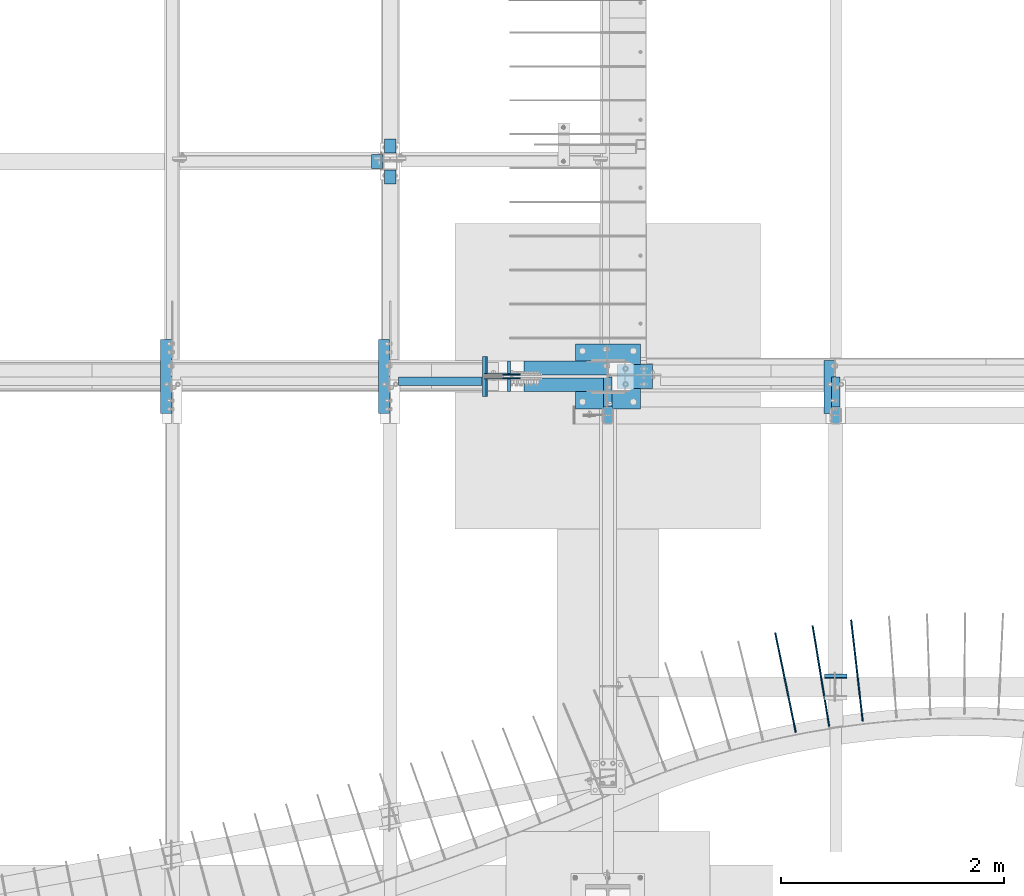
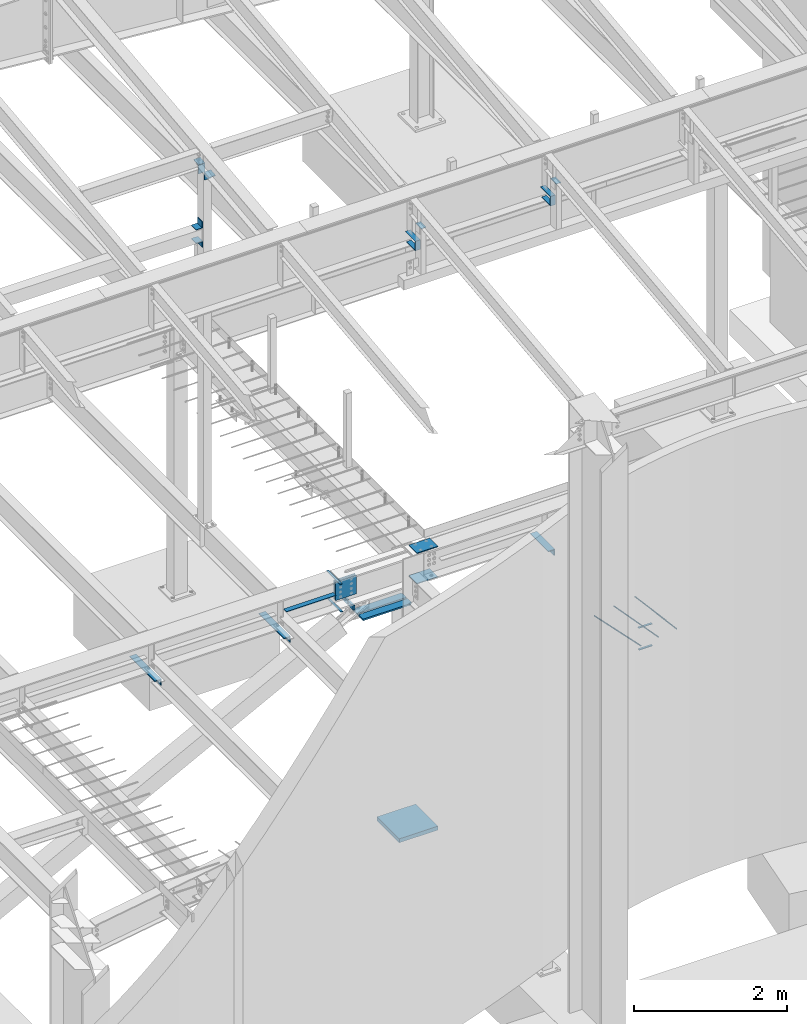
# One storey, part 809 of 1179: 28 beams, 18 elements without a shape of their own.
"""IFC2X3 building model written with IfcOpenShell, lengths in millimetres."""

import ifcopenshell
import ifcopenshell.guid

model = None  # the IFC model being written
_history = None  # IfcOwnerHistory: only IFC2X3 demands one
_inside = {}  # id of a spatial element -> (the spatial element, [elements in it])
_under = {}  # id of a project, library or spatial element -> (it, [spatial elements below it])
_declared = {}  # id of a project -> (the project, [libraries it declares])
_typed = {}  # id of a type object -> (the type object, [elements of that type])
_made_of = {}  # id of a material, layer set ... -> (it, [elements and type objects made of it])


def new_model(schema):
    """Start an empty IFC model of exactly this schema.

    Asked for "IFC4X3", IfcOpenShell would pick the latest addendum, in which some entities
    have other attributes; the version numbers below select the first issue.
    IFC2X3 requires an IfcOwnerHistory on every rooted entity: one is made here for all.
    """
    global model, _history
    if schema == "IFC4X3":
        model = ifcopenshell.file(schema_version=(4, 3, 0, 0))
    else:
        model = ifcopenshell.file(schema=schema)
    _inside.clear()
    _under.clear()
    _declared.clear()
    _typed.clear()
    _made_of.clear()
    _history = None
    if model.schema == "IFC2X3":
        org = make("IfcOrganization", Name="unknown")
        user = make(
            "IfcPersonAndOrganization",
            ThePerson=make("IfcPerson", FamilyName="unknown"),
            TheOrganization=org,
        )
        app = make(
            "IfcApplication",
            ApplicationDeveloper=org,
            Version="unknown",
            ApplicationFullName="unknown",
            ApplicationIdentifier="unknown",
        )
        _history = make(
            "IfcOwnerHistory",
            OwningUser=user,
            OwningApplication=app,
            ChangeAction="ADDED",
            CreationDate=0,
        )
    return model


def make(cls, **values):
    """One entity of the class cls with the attributes given. An attribute that is None is left unset."""
    return model.create_entity(
        cls, **{name: value for name, value in values.items() if value is not None}
    )


def rooted(cls, **values):
    """An entity with a GlobalId (a new one), such as an element, a storey or a relation."""
    return make(cls, GlobalId=ifcopenshell.guid.new(), OwnerHistory=_history, **values)


def si_unit(unit_type, name, prefix=None):
    """IfcSIUnit, for example si_unit("LENGTHUNIT", "METRE", prefix="MILLI")."""
    return make("IfcSIUnit", UnitType=unit_type, Prefix=prefix, Name=name)


def assignment(units):
    """IfcUnitAssignment: the units of a project."""
    return None if units is None else make("IfcUnitAssignment", Units=units)


def point(xyz):
    """IfcCartesianPoint."""
    return None if xyz is None else make("IfcCartesianPoint", Coordinates=xyz)


def direction(xyz):
    """IfcDirection."""
    return None if xyz is None else make("IfcDirection", DirectionRatios=xyz)


def frame(location, z_axis=None, x_axis=None):
    """IfcAxis2Placement3D, a coordinate frame: its origin and axes. An axis left out is left unset."""
    return make(
        "IfcAxis2Placement3D",
        Location=point(location),
        Axis=direction(z_axis),
        RefDirection=direction(x_axis),
    )


def origin_with_axes():
    """The frame at (0, 0, 0) with the z axis (0, 0, 1) and the x axis (1, 0, 0) written out."""
    return frame((0.0, 0.0, 0.0), z_axis=(0.0, 0.0, 1.0), x_axis=(1.0, 0.0, 0.0))


def place(relative_to, where):
    """IfcLocalPlacement: puts the frame where relative to a parent placement (None: the world)."""
    return make(
        "IfcLocalPlacement", PlacementRelTo=relative_to, RelativePlacement=where
    )


def context(
    kind, dimensions, precision=None, world=None, true_north=None, identifier=None
):
    """IfcGeometricRepresentationContext, for example the 3D "Model" context."""
    return make(
        "IfcGeometricRepresentationContext",
        ContextIdentifier=identifier,
        ContextType=kind,
        CoordinateSpaceDimension=dimensions,
        Precision=precision,
        WorldCoordinateSystem=world,
        TrueNorth=true_north,
    )


def subcontext(parent, identifier, kind, view, scale=None):
    """IfcGeometricRepresentationSubContext, for example "Body" below "Model"."""
    return make(
        "IfcGeometricRepresentationSubContext",
        ContextIdentifier=identifier,
        ContextType=kind,
        ParentContext=parent,
        TargetScale=scale,
        TargetView=view,
    )


def project(units=None, contexts=None):
    """IfcProject with its units and contexts."""
    return rooted(
        "IfcProject",
        Name="project",
        RepresentationContexts=contexts,
        UnitsInContext=assignment(units),
    )


def spatial(cls, under=None, at=None, **own):
    """A site, building, storey or space (cls), placed at a placement, below another one or the project."""
    s = rooted(cls, ObjectPlacement=at, **own)
    if under is not None:
        _under.setdefault(under.id(), (under, []))[1].append(s)
    return s


def faces_of(points, faces, orient=None, outer=None):
    """IfcFace entities. A face is a list of loops; a loop is a list of indices into points, from 0.

    orient and outer hold one flag for each loop. By default every Orientation is true, the
    first loop of a face is its IfcFaceOuterBound and the others are IfcFaceBound.
    """
    made = []
    for i, loops in enumerate(faces):
        bounds = []
        for j, loop in enumerate(loops):
            is_outer = j == 0 if outer is None else outer[i][j]
            bounds.append(
                make(
                    "IfcFaceOuterBound" if is_outer else "IfcFaceBound",
                    Bound=make("IfcPolyLoop", Polygon=[points[k] for k in loop]),
                    Orientation=True if orient is None else orient[i][j],
                )
            )
        made.append(make("IfcFace", Bounds=bounds))
    return made


def faceted_brep(points, faces, orient=None, outer=None, voids=None):
    """IfcFacetedBrep: a solid bounded by flat faces; with voids (closed shells), ...WithVoids."""
    shared = [point(p) for p in points]
    hull = make("IfcClosedShell", CfsFaces=faces_of(shared, faces, orient, outer))
    if voids is None:
        return make("IfcFacetedBrep", Outer=hull)
    return make(
        "IfcFacetedBrepWithVoids",
        Outer=hull,
        Voids=[
            make(cls, CfsFaces=faces_of(shared, fs, o, b)) for cls, fs, o, b in voids
        ],
    )


def shape(context_of_items, identifier, shape_type, items):
    """IfcShapeRepresentation: the items that make up one representation, for example the "Body"."""
    return make(
        "IfcShapeRepresentation",
        ContextOfItems=context_of_items,
        RepresentationIdentifier=identifier,
        RepresentationType=shape_type,
        Items=items,
    )


def material(Name=None, Category=None):
    """IfcMaterial."""
    return make("IfcMaterial", Name=Name, Category=Category)


def made_of(thing, what):
    """Note that an element or type object is made of a material, layer set ...; save() writes the relation."""
    if what is not None:
        _made_of.setdefault(what.id(), (what, []))[1].append(thing)
    return thing


def type_object(cls, material=None, **own):
    """A type object (cls), such as IfcWallType, which elements share."""
    return made_of(rooted(cls, **own), material)


def element(
    cls,
    number,
    at=None,
    inside=None,
    cuts=None,
    type_object=None,
    material=None,
    context=None,
    identifier="Body",
    shape_type=None,
    held_by="IfcProductDefinitionShape",
    body=None,
    shapes=None,
    **own,
):
    """One element of the class cls, such as IfcWall. Its Tag is "e" and its number.

    at: its placement. inside: the storey or other place that contains it. cuts: it is an
    opening in that element (IfcRelVoidsElement). A single representation is given by context,
    identifier, shape_type and body (its items); several are given by shapes. held_by: the class
    of the entity that holds the representations. save() writes the other relations.
    """
    e = rooted(cls, Tag="e%d" % number, ObjectPlacement=at, **own)
    if body is not None:
        shapes = [shape(context, identifier, shape_type, body)]
    if shapes is not None:
        e.Representation = make(held_by, Representations=shapes)
    if inside is not None:
        _inside.setdefault(inside.id(), (inside, []))[1].append(e)
    if cuts is not None:
        rooted(
            "IfcRelVoidsElement", RelatingBuildingElement=cuts, RelatedOpeningElement=e
        )
    if type_object is not None:
        _typed.setdefault(type_object.id(), (type_object, []))[1].append(e)
    return made_of(e, material)


def aggregate(whole, parts):
    """IfcRelAggregates: a whole, such as a stair, and the parts it consists of."""
    return rooted("IfcRelAggregates", RelatingObject=whole, RelatedObjects=parts)


def save(model, path):
    """Write the relations noted so far, then the file.

    IfcRelAggregates (storeys below a building ...), IfcRelContainedInSpatialStructure (elements
    in a storey), IfcRelDefinesByType, IfcRelAssociatesMaterial and IfcRelDeclares: one each for
    every whole, place, type object, material and project.
    """
    for whole, parts in _under.values():
        aggregate(whole, parts)
    for where, things in _inside.values():
        rooted(
            "IfcRelContainedInSpatialStructure",
            RelatedElements=things,
            RelatingStructure=where,
        )
    for kind, things in _typed.values():
        rooted("IfcRelDefinesByType", RelatedObjects=things, RelatingType=kind)
    for what, things in _made_of.values():
        rooted("IfcRelAssociatesMaterial", RelatedObjects=things, RelatingMaterial=what)
    for by, libraries in _declared.values():
        rooted("IfcRelDeclares", RelatingContext=by, RelatedDefinitions=libraries)
    model.write(path)


model = new_model("IFC2X3")

# Units and contexts
model_context = context("Model", 3, precision=1e-05, world=origin_with_axes())
body_context = subcontext(model_context, "Body", "Model", "MODEL_VIEW")
ifc_project = project(units=[si_unit("LENGTHUNIT", "METRE", prefix="MILLI"), si_unit("AREAUNIT", "SQUARE_METRE"), si_unit("VOLUMEUNIT", "CUBIC_METRE"), si_unit("MASSUNIT", "GRAM", prefix="KILO"), si_unit("TIMEUNIT", "SECOND"), si_unit("PLANEANGLEUNIT", "RADIAN"), si_unit("SOLIDANGLEUNIT", "STERADIAN"), si_unit("THERMODYNAMICTEMPERATUREUNIT", "DEGREE_CELSIUS"), si_unit("LUMINOUSINTENSITYUNIT", "LUMEN")], contexts=[model_context])

# Site, building, storey
site_placement = place(None, origin_with_axes())
site = spatial("IfcSite", under=ifc_project, at=site_placement, CompositionType="ELEMENT")
building_placement = place(site_placement, origin_with_axes())
building = spatial("IfcBuilding", under=site, at=building_placement, Name="Undefined", CompositionType="ELEMENT")
storey_placement = place(building_placement, origin_with_axes())
storey = spatial("IfcBuildingStorey", under=building, at=storey_placement, Name="Undefined", CompositionType="ELEMENT", Elevation=0.0)

# Assembly, beam
assembly_1_placement = place(storey_placement, origin_with_axes())
assembly_1 = element("IfcElementAssembly", 1, at=assembly_1_placement, inside=storey, Name="BEAM", AssemblyPlace="NOTDEFINED", PredefinedType="RIGID_FRAME")
ifc_material_1 = material(Name="STEEL/A36")
beam_type_1 = type_object("IfcBeamType", PredefinedType="NOTDEFINED")
beam_1_placement = place(assembly_1_placement, frame((6324.59996446262, 7446.9625, 9630.48766950149), z_axis=(-1.0, 0.0, 0.0), x_axis=(0.0, 0.0, 1.0)))
beam_1 = element("IfcBeam", 2, at=beam_1_placement, type_object=beam_type_1, material=ifc_material_1, Name="BENT_PLATE", context=body_context, shape_type="Brep", body=[
    faceted_brep([(0.0, -4.76249999999982, -50.7999999999993), (0.0, -4.76249999999982, 50.7999999999993), (0.0, 4.76249999999982, 50.7999999999993), (0.0, 4.76249999999982, -50.7999999999993), (135.885033717501, 4.76249999999982, 50.8000000000002), (135.885033717501, 4.76249999999982, -50.8000000000002), (144.398796748286, -4.76249999999982, -50.8000000000002), (144.398796748286, -4.76249999999982, 50.8000000000002), (149.127881995584, 122.50635470422, 50.8000000000002), (149.127881995584, 122.50635470422, -50.8000000000002), (158.593202565677, 121.441774267915, 50.8000000000002), (158.593202565677, 121.441774267915, -50.8000000000002)], [[[0, 1, 2, 3]], [[3, 2, 4, 5]], [[1, 0, 6, 7]], [[5, 4, 8, 9]], [[4, 2, 1, 7, 10, 8]], [[7, 6, 11, 10]], [[6, 0, 3, 5, 9, 11]], [[10, 11, 9, 8]]]),
])
aggregate(assembly_1, [beam_1])

assembly_2_placement = place(storey_placement, origin_with_axes())
assembly_2 = element("IfcElementAssembly", 3, at=assembly_2_placement, inside=storey, Name="COLUMN", AssemblyPlace="NOTDEFINED", PredefinedType="RIGID_FRAME")
beam_2_placement = place(assembly_2_placement, frame((6324.59996446262, 7164.15192308151, 9738.49520780131), z_axis=(1.0, 0.0, 0.0), x_axis=(0.0, 0.993676146336441, 0.112284087038017)))
beam_2 = element("IfcBeam", 4, at=beam_2_placement, type_object=beam_type_1, material=ifc_material_1, Name="BENT_PLATE", context=body_context, shape_type="Brep", body=[
    faceted_brep([(0.0, -4.76249999999982, -50.7999999999993), (0.0, -4.76249999999982, 50.7999999999993), (0.0, 4.76249999999982, 50.7999999999993), (0.0, 4.76249999999982, -50.7999999999993), (127.000000000371, 4.76249999928405, 50.8000000000002), (127.000000000371, 4.76249999928405, -50.8000000000002), (116.338069583646, -4.76250000065011, -50.8000000000002), (116.338069583646, -4.76250000065011, 50.8000000000002), (112.73992094698, -121.434370585366, 50.8000000000002), (112.73992094698, -121.434370585366, -50.8000000000002), (103.275155653118, -120.364864656354, 50.8000000000002), (103.275155653118, -120.364864656354, -50.8000000000002)], [[[0, 1, 2, 3]], [[3, 2, 4, 5]], [[1, 0, 6, 7]], [[5, 4, 8, 9]], [[4, 2, 1, 7, 10, 8]], [[7, 6, 11, 10]], [[6, 0, 3, 5, 9, 11]], [[10, 11, 9, 8]]]),
])

assembly_3_placement = place(storey_placement, origin_with_axes())
assembly_3 = element("IfcElementAssembly", 5, at=assembly_3_placement, inside=storey, Name="COLUMN", AssemblyPlace="NOTDEFINED", PredefinedType="RIGID_FRAME")
beam_type_2 = type_object("IfcBeamType", PredefinedType="NOTDEFINED")
beam_3_placement = place(assembly_3_placement, frame((10325.1, 5010.15, 9537.09726511864), z_axis=(1.0, 0.0, 0.0), x_axis=(0.0, 1.0, 0.0)))
beam_3 = element("IfcBeam", 6, at=beam_3_placement, type_object=beam_type_2, material=ifc_material_1, Name="PLATE", context=body_context, shape_type="Brep", body=[
    faceted_brep([(0.0, 2.38149999999951, -38.0999999999985), (0.0, 2.38149999999951, 38.0999999999985), (152.4, 2.38149999999951, 38.0999999999985), (152.4, 2.38149999999951, -38.0999999999985), (0.0, -2.38149999999951, 38.0999999999985), (152.4, -2.38149999999951, 38.0999999999985), (0.0, -2.38149999999951, -38.0999999999985), (152.4, -2.38149999999951, -38.0999999999985)], [[[0, 1, 2, 3]], [[1, 4, 5, 2]], [[4, 6, 7, 5]], [[6, 0, 3, 7]], [[5, 7, 3, 2]], [[6, 4, 1, 0]]]),
])
aggregate(assembly_3, [beam_3])

assembly_4_placement = place(storey_placement, origin_with_axes())
assembly_4 = element("IfcElementAssembly", 7, at=assembly_4_placement, inside=storey, Name="COLUMN", AssemblyPlace="NOTDEFINED", PredefinedType="RIGID_FRAME")
beam_4_placement = place(assembly_4_placement, frame((8280.4, 5010.15, 9537.09726511864), z_axis=(1.0, 0.0, 0.0), x_axis=(0.0, 1.0, 0.0)))
beam_4 = element("IfcBeam", 8, at=beam_4_placement, type_object=beam_type_2, material=ifc_material_1, Name="PLATE", context=body_context, shape_type="Brep", body=[
    faceted_brep([(0.0, 2.38149999999951, -38.0999999999985), (0.0, 2.38149999999951, 38.0999999999985), (152.4, 2.38149999999951, 38.0999999999985), (152.4, 2.38149999999951, -38.0999999999985), (0.0, -2.38149999999951, 38.0999999999985), (152.4, -2.38149999999951, 38.0999999999985), (0.0, -2.38149999999951, -38.0999999999985), (152.4, -2.38149999999951, -38.0999999999985)], [[[0, 1, 2, 3]], [[1, 4, 5, 2]], [[4, 6, 7, 5]], [[6, 0, 3, 7]], [[5, 7, 3, 2]], [[6, 4, 1, 0]]]),
])
aggregate(assembly_4, [beam_4])

assembly_5_placement = place(storey_placement, origin_with_axes())
assembly_5 = element("IfcElementAssembly", 9, at=assembly_5_placement, inside=storey, Name="BEAM", AssemblyPlace="NOTDEFINED", PredefinedType="RIGID_FRAME")
beam_type_3 = type_object("IfcBeamType", Name="L4X4X1/2", PredefinedType="NOTDEFINED")
beam_5_placement = place(assembly_5_placement, frame((4314.8245859597, 5103.81235642284, 3584.575), z_axis=(0.0, 0.0, -1.0), x_axis=(0.0, 1.0, 0.0)))
beam_5 = element("IfcBeam", 10, at=beam_5_placement, type_object=beam_type_3, material=ifc_material_1, Name="ANGLE", ObjectType="L4X4X1/2", context=body_context, shape_type="Brep", body=[
    faceted_brep([(1.90993887372315e-11, 50.8000000000002, -50.8000000000002), (1.90993887372315e-11, 50.8000000000002, 50.8000000000002), (663.574996948242, 50.8000000000002, 50.8000000000002), (663.574996948242, 50.8000000000002, -50.8000000000002), (1.45519152283669e-11, 38.1000000000004, 50.8000000000002), (663.574996948242, 38.1000000000004, 50.8000000000002), (0.0, 38.0999999999985, -38.0999999999999), (663.574996948242, 38.1000000000004, -38.0999999999999), (-1.81898940354586e-11, -50.7999999999997, -38.0999999999999), (663.574996948242, -50.8000000000002, -38.0999999999999), (-1.81898940354586e-11, -50.7999999999997, -50.8000000000002), (663.574996948242, -50.8000000000002, -50.8000000000002)], [[[0, 1, 2, 3]], [[1, 4, 5, 2]], [[4, 6, 7, 5]], [[6, 8, 9, 7]], [[8, 10, 11, 9]], [[10, 0, 3, 11]], [[5, 7, 9, 11, 3, 2]], [[10, 8, 6, 4, 1, 0]]]),
])

assembly_6_placement = place(storey_placement, origin_with_axes())
assembly_6 = element("IfcElementAssembly", 11, at=assembly_6_placement, inside=storey, Name="BEAM", AssemblyPlace="NOTDEFINED", PredefinedType="RIGID_FRAME")
beam_6_placement = place(assembly_6_placement, frame((10271.1249998114, 5103.8125046857, 3578.225), z_axis=(0.0, 0.0, -1.0), x_axis=(0.0, 1.0, 0.0)))
beam_6 = element("IfcBeam", 12, at=beam_6_placement, type_object=beam_type_3, material=ifc_material_1, Name="ANGLE", ObjectType="L4X4X1/2", context=body_context, shape_type="Brep", body=[
    faceted_brep([(1.90993887372315e-11, 50.8000000000002, -50.8000000000002), (1.90993887372315e-11, 50.8000000000002, 50.8000000000002), (473.074997024448, 50.8000000002612, 50.8000000000002), (473.074997024448, 50.8000000002612, -50.8000000000002), (1.45519152283669e-11, 38.1000000000004, 50.8000000000002), (473.074997024443, 38.1000000002623, 50.8000000000002), (0.0, 38.0999999999985, -38.0999999999999), (473.074997024443, 38.1000000002623, -38.0999999999999), (-1.81898940354586e-11, -50.7999999999997, -38.0999999999999), (473.074997024411, -50.7999999997392, -38.0999999999999), (-1.81898940354586e-11, -50.7999999999997, -50.8000000000002), (473.074997024411, -50.7999999997392, -50.8000000000002)], [[[0, 1, 2, 3]], [[1, 4, 5, 2]], [[4, 6, 7, 5]], [[6, 8, 9, 7]], [[8, 10, 11, 9]], [[10, 0, 3, 11]], [[5, 7, 9, 11, 3, 2]], [[10, 8, 6, 4, 1, 0]]]),
])
aggregate(assembly_6, [beam_6])

# Beam
beam_7_placement = place(assembly_5_placement, frame((6270.62446379268, 5103.81250474718, 3584.575), z_axis=(0.0, 0.0, -1.0), x_axis=(0.0, 1.0, 0.0)))
beam_7 = element("IfcBeam", 13, at=beam_7_placement, type_object=beam_type_3, material=ifc_material_1, Name="ANGLE", ObjectType="L4X4X1/2", context=body_context, shape_type="Brep", body=[
    faceted_brep([(1.90993887372315e-11, 50.8000000000002, -50.8000000000002), (1.90993887372315e-11, 50.8000000000002, 50.8000000000002), (663.574996948242, 50.8000000000002, 50.8000000000002), (663.574996948242, 50.8000000000002, -50.8000000000002), (1.45519152283669e-11, 38.1000000000004, 50.8000000000002), (663.574996948242, 38.1000000000004, 50.8000000000002), (0.0, 38.0999999999985, -38.0999999999999), (663.574996948242, 38.1000000000004, -38.0999999999999), (-1.81898940354586e-11, -50.7999999999997, -38.0999999999999), (663.574996948242, -50.8000000000002, -38.0999999999999), (-1.81898940354586e-11, -50.7999999999997, -50.8000000000002), (663.574996948242, -50.8000000000002, -50.8000000000002)], [[[0, 1, 2, 3]], [[1, 4, 5, 2]], [[4, 6, 7, 5]], [[6, 8, 9, 7]], [[8, 10, 11, 9]], [[10, 0, 3, 11]], [[5, 7, 9, 11, 3, 2]], [[10, 8, 6, 4, 1, 0]]]),
])

ifc_material_2 = material(Name="STEEL/A572-GR.50")
beam_type_4 = type_object("IfcBeamType", PredefinedType="NOTDEFINED")
beam_8_placement = place(assembly_5_placement, frame((7167.86513966962, 5435.60003662087, 3630.6125), z_axis=(0.0, -1.0, 0.0), x_axis=(1.0, 0.0, 0.0)))
beam_8 = element("IfcBeam", 14, at=beam_8_placement, type_object=beam_type_4, material=ifc_material_2, Name="PLATE", context=body_context, shape_type="Brep", body=[
    faceted_brep([(0.0, 4.76249999999982, -179.3875), (0.0, 4.76249999999982, 179.3875), (31.7500000000036, 4.76249999999982, 179.3875), (31.7500000000036, 4.76249999999982, -179.3875), (0.0, -4.76249999999982, 179.3875), (31.7500000000036, -4.76249999999982, 179.3875), (0.0, -4.76249999999982, -179.3875), (31.7500000000036, -4.76249999999982, -179.3875)], [[[0, 1, 2, 3]], [[1, 4, 5, 2]], [[4, 6, 7, 5]], [[6, 0, 3, 7]], [[5, 7, 3, 2]], [[6, 4, 1, 0]]]),
])

beam_9_placement = place(assembly_5_placement, frame((7155.97922453646, 5435.60003662087, 4077.8905), z_axis=(0.0, -1.0, 0.0), x_axis=(1.0, 0.0, 0.0)))
beam_9 = element("IfcBeam", 15, at=beam_9_placement, type_object=beam_type_4, material=ifc_material_2, Name="PLATE", context=body_context, shape_type="Brep", body=[
    faceted_brep([(0.0, 4.76249999999982, -179.3875), (0.0, 4.76249999999982, 179.3875), (31.7500000000036, 4.76249999999982, 179.3875), (31.7500000000036, 4.76249999999982, -179.3875), (0.0, -4.76249999999982, 179.3875), (31.7500000000036, -4.76249999999982, 179.3875), (0.0, -4.76249999999982, -179.3875), (31.7500000000036, -4.76249999999982, -179.3875)], [[[0, 1, 2, 3]], [[1, 4, 5, 2]], [[4, 6, 7, 5]], [[6, 0, 3, 7]], [[5, 7, 3, 2]], [[6, 4, 1, 0]]]),
])

# Assembly, beams
assembly_7_placement = place(storey_placement, origin_with_axes())
assembly_7 = element("IfcElementAssembly", 16, at=assembly_7_placement, inside=storey, Name="BEAM", AssemblyPlace="NOTDEFINED", PredefinedType="RIGID_FRAME")
beam_10_placement = place(assembly_7_placement, frame((10325.1, 2733.675, 3831.8280002594), z_axis=(-1.0, 0.0, 0.0), x_axis=(0.0, 1.0, 0.0)))
beam_10 = element("IfcBeam", 17, at=beam_10_placement, type_object=beam_type_4, material=ifc_material_1, Name="PLATE", context=body_context, shape_type="Brep", body=[
    faceted_brep([(0.0, 4.76250000000073, -101.6), (0.0, 4.76250000000073, 101.6), (31.75, 4.76249999999982, 101.6), (31.75, 4.76249999999982, -101.6), (0.0, -4.76250000000073, 101.6), (31.75, -4.76249999999982, 101.6), (0.0, -4.76250000000073, -101.6), (31.75, -4.76249999999982, -101.6)], [[[0, 1, 2, 3]], [[1, 4, 5, 2]], [[4, 6, 7, 5]], [[6, 0, 3, 7]], [[5, 7, 3, 2]], [[6, 4, 1, 0]]]),
])
beam_11_placement = place(assembly_7_placement, frame((10325.1, 2722.56287436933, 3490.9125), z_axis=(-1.0, 0.0, 0.0), x_axis=(0.0, 1.0, 0.0)))
beam_11 = element("IfcBeam", 18, at=beam_11_placement, type_object=beam_type_4, material=ifc_material_1, Name="PLATE", context=body_context, shape_type="Brep", body=[
    faceted_brep([(0.0, 4.76250000000073, -101.6), (0.0, 4.76250000000073, 101.6), (31.75, 4.76249999999982, 101.6), (31.75, 4.76249999999982, -101.6), (0.0, -4.76250000000073, 101.6), (31.75, -4.76249999999982, 101.6), (0.0, -4.76250000000073, -101.6), (31.75, -4.76249999999982, -101.6)], [[[0, 1, 2, 3]], [[1, 4, 5, 2]], [[4, 6, 7, 5]], [[6, 0, 3, 7]], [[5, 7, 3, 2]], [[6, 4, 1, 0]]]),
])
aggregate(assembly_7, [beam_10, beam_11])

# Beam
beam_type_5 = type_object("IfcBeamType", Name="L4X4X3/8", PredefinedType="NOTDEFINED")
beam_12_placement = place(assembly_2_placement, frame((6210.29996446262, 7302.5, 8597.9), z_axis=(0.0, 0.0, -1.0), x_axis=(0.0, 1.0, 0.0)))
beam_12 = element("IfcBeam", 19, at=beam_12_placement, type_object=beam_type_5, material=ifc_material_1, Name="ANGLE", ObjectType="L4X4X3/8", context=body_context, shape_type="Brep", body=[
    faceted_brep([(1.90993887372315e-11, 50.8000000000002, -50.8000000000002), (1.90993887372315e-11, 50.8000000000002, 50.8000000000002), (126.999999999993, 50.8000000000002, 50.7999999999993), (126.999999999993, 50.8000000000002, -50.7999999999993), (0.0, 41.2750000000015, 50.8000000000029), (126.999999999993, 41.2749999999996, 50.7999999999993), (0.0, 41.2750000000015, -41.2750000000015), (126.999999999993, 41.2749999999996, -41.2749999999996), (0.0, -50.7999999999993, -41.2750000000015), (126.999999999993, -50.8000000000002, -41.2749999999996), (-1.81898940354586e-11, -50.7999999999997, -50.8000000000002), (126.999999999993, -50.8000000000002, -50.7999999999993)], [[[0, 1, 2, 3]], [[1, 4, 5, 2]], [[4, 6, 7, 5]], [[6, 8, 9, 7]], [[8, 10, 11, 9]], [[10, 0, 3, 11]], [[5, 7, 9, 11, 3, 2]], [[10, 8, 6, 4, 1, 0]]]),
])

beam_13_placement = place(assembly_2_placement, frame((6210.29996446262, 7302.5, 8904.2875), z_axis=(-1.0, 0.0, 0.0), x_axis=(0.0, 1.0, 0.0)))
beam_13 = element("IfcBeam", 20, at=beam_13_placement, type_object=beam_type_5, material=ifc_material_1, Name="ANGLE", ObjectType="L4X4X3/8", context=body_context, shape_type="Brep", body=[
    faceted_brep([(1.90993887372315e-11, 50.8000000000002, -50.8000000000002), (1.90993887372315e-11, 50.8000000000002, 50.8000000000002), (126.999999999993, 50.8000000000002, 50.7999999999993), (126.999999999993, 50.8000000000002, -50.7999999999993), (0.0, 41.2750000000015, 50.8000000000029), (126.999999999993, 41.2749999999996, 50.7999999999993), (0.0, 41.2750000000015, -41.2750000000015), (126.999999999993, 41.2749999999996, -41.2749999999996), (0.0, -50.7999999999993, -41.2750000000015), (126.999999999993, -50.8000000000002, -41.2749999999996), (-1.81898940354586e-11, -50.7999999999997, -50.8000000000002), (126.999999999993, -50.8000000000002, -50.7999999999993)], [[[0, 1, 2, 3]], [[1, 4, 5, 2]], [[4, 6, 7, 5]], [[6, 8, 9, 7]], [[8, 10, 11, 9]], [[10, 0, 3, 11]], [[5, 7, 9, 11, 3, 2]], [[10, 8, 6, 4, 1, 0]]]),
])

aggregate(assembly_2, [beam_2, beam_12, beam_13])

# Assembly, beams
assembly_8_placement = place(storey_placement, origin_with_axes())
assembly_8 = element("IfcElementAssembly", 21, at=assembly_8_placement, inside=storey, Name="COLUMN", AssemblyPlace="NOTDEFINED", PredefinedType="RIGID_FRAME")
beam_type_6 = type_object("IfcBeamType", PredefinedType="NOTDEFINED")
beam_14_placement = place(assembly_8_placement, frame((8362.15625000001, 5435.6, 3622.675), z_axis=(0.0, -1.0, 0.0), x_axis=(1.0, 0.0, 0.0)))
beam_14 = element("IfcBeam", 22, at=beam_14_placement, type_object=beam_type_6, material=ifc_material_2, Name="PLATE", context=body_context, shape_type="Brep", body=[
    faceted_brep([(0.0, 6.35000000000036, -107.949999999997), (0.0, 6.35000000000036, 107.949999999997), (316.706250012867, 6.35000000000036, 107.949999999997), (316.706250012867, 6.35000000000036, -107.949999999997), (0.0, -6.35000000000036, 107.949999999997), (316.706250012867, -6.35000000000036, 107.949999999997), (0.0, -6.35000000000036, -107.949999999997), (316.706250012867, -6.35000000000036, -107.949999999997)], [[[0, 1, 2, 3]], [[1, 4, 5, 2]], [[4, 6, 7, 5]], [[6, 0, 3, 7]], [[5, 7, 3, 2]], [[6, 4, 1, 0]]]),
])
beam_15_placement = place(assembly_8_placement, frame((8362.15625, 5435.6, 4108.45), z_axis=(0.0, -1.0, 0.0), x_axis=(1.0, 0.0, 0.0)))
beam_15 = element("IfcBeam", 23, at=beam_15_placement, type_object=beam_type_6, material=ifc_material_2, Name="PLATE", context=body_context, shape_type="Brep", body=[
    faceted_brep([(0.0, 6.35000000000036, -107.949999999997), (0.0, 6.35000000000036, 107.949999999997), (316.706250012867, 6.35000000000036, 107.949999999997), (316.706250012867, 6.35000000000036, -107.949999999997), (0.0, -6.35000000000036, 107.949999999997), (316.706250012867, -6.35000000000036, 107.949999999997), (0.0, -6.35000000000036, -107.949999999997), (316.706250012867, -6.35000000000036, -107.949999999997)], [[[0, 1, 2, 3]], [[1, 4, 5, 2]], [[4, 6, 7, 5]], [[6, 0, 3, 7]], [[5, 7, 3, 2]], [[6, 4, 1, 0]]]),
])

assembly_9_placement = place(storey_placement, origin_with_axes())
assembly_9 = element("IfcElementAssembly", 24, at=assembly_9_placement, inside=storey, Name="BEAM", AssemblyPlace="NOTDEFINED", PredefinedType="RIGID_FRAME")
beam_type_7 = type_object("IfcBeamType", PredefinedType="NOTDEFINED")
beam_16_placement = place(assembly_9_placement, frame((10325.1, 5428.96334528892, 9242.7162842795), z_axis=(-1.0, 0.0, 0.0), x_axis=(0.0, -1.0, 0.0)))
beam_16 = element("IfcBeam", 25, at=beam_16_placement, type_object=beam_type_7, material=ifc_material_1, Name="BENT_PLATE", context=body_context, shape_type="Brep", body=[
    faceted_brep([(0.0, -3.17499999999927, -38.0999999999985), (0.0, -3.17499999999927, 38.0999999999985), (0.0, 3.17499999999927, 38.0999999999985), (0.0, 3.17499999999927, -38.0999999999985), (266.413345280603, 3.17499999999927, 38.1000000000004), (266.413345280603, 3.17499999999927, -38.1000000000004), (260.063345280949, -3.17499999999927, -38.1000000000004), (260.063345280949, -3.17499999999927, 38.1000000000004), (266.413345288925, -149.225000000002, 38.1000000000004), (266.413345288925, -149.225000000002, -38.1000000000004), (260.063345288579, -142.875000000004, -38.1000000000004), (260.063345288579, -142.875000000004, 38.1000000000004), (31.7499999989141, -149.225000000002, 38.1000000000004), (31.7499999989141, -149.225000000002, -38.1000000000004), (31.7499999989141, -142.875000000004, 38.1000000000004), (31.7499999989141, -142.875000000004, -38.1000000000004)], [[[0, 1, 2, 3]], [[3, 2, 4, 5]], [[1, 0, 6, 7]], [[5, 4, 8, 9]], [[7, 6, 10, 11]], [[9, 8, 12, 13]], [[8, 4, 2, 1, 7, 11, 14, 12]], [[11, 10, 15, 14]], [[10, 6, 0, 3, 5, 9, 13, 15]], [[14, 15, 13, 12]]]),
])
beam_17_placement = place(assembly_9_placement, frame((8280.4, 5428.96334528892, 9242.7162842795), z_axis=(-1.0, 0.0, 0.0), x_axis=(0.0, -1.0, 0.0)))
beam_17 = element("IfcBeam", 26, at=beam_17_placement, type_object=beam_type_7, material=ifc_material_1, Name="BENT_PLATE", context=body_context, shape_type="Brep", body=[
    faceted_brep([(0.0, -3.17499999999927, -38.0999999999985), (0.0, -3.17499999999927, 38.0999999999985), (0.0, 3.17499999999927, 38.0999999999985), (0.0, 3.17499999999927, -38.0999999999985), (266.413345280603, 3.17499999999927, 38.1000000000004), (266.413345280603, 3.17499999999927, -38.1000000000004), (260.063345280949, -3.17499999999927, -38.1000000000004), (260.063345280949, -3.17499999999927, 38.1000000000004), (266.413345288925, -149.225000000002, 38.1000000000004), (266.413345288925, -149.225000000002, -38.1000000000004), (260.063345288579, -142.875000000004, -38.1000000000004), (260.063345288579, -142.875000000004, 38.1000000000004), (31.7499999989141, -149.225000000002, 38.1000000000004), (31.7499999989141, -149.225000000002, -38.1000000000004), (31.7499999989141, -142.875000000004, 38.1000000000004), (31.7499999989141, -142.875000000004, -38.1000000000004)], [[[0, 1, 2, 3]], [[3, 2, 4, 5]], [[1, 0, 6, 7]], [[5, 4, 8, 9]], [[7, 6, 10, 11]], [[9, 8, 12, 13]], [[8, 4, 2, 1, 7, 11, 14, 12]], [[11, 10, 15, 14]], [[10, 6, 0, 3, 5, 9, 13, 15]], [[14, 15, 13, 12]]]),
])
aggregate(assembly_9, [beam_16, beam_17])

# Assembly, beam
assembly_10_placement = place(storey_placement, origin_with_axes())
assembly_10 = element("IfcElementAssembly", 27, at=assembly_10_placement, inside=storey, Name="PLATE", AssemblyPlace="NOTDEFINED", PredefinedType="RIGID_FRAME")
beam_type_8 = type_object("IfcBeamType", PredefinedType="NOTDEFINED")
beam_18_placement = place(assembly_10_placement, frame((8274.84375002286, 5360.1935, 3352.55931828175), z_axis=(0.0, 1.0, 0.0), x_axis=(-1.0, 0.0, 0.0)))
beam_18 = element("IfcBeam", 28, at=beam_18_placement, type_object=beam_type_8, material=ifc_material_2, Name="PLATE", context=body_context, shape_type="Brep", body=[
    faceted_brep([(22.2249999999985, -12.6999999999998, -61.1189999999997), (0.0, -12.6999999999998, -38.8940000000002), (0.0, 12.6999999999998, -38.8940000000002), (22.2249999999985, 12.6999999999998, -61.1189999999997), (0.0, 12.7, 61.1189999999988), (746.344049928996, 12.6999999999998, 61.1189999999997), (746.344049928996, 12.6999999999998, -61.1189999999997), (0.0, -12.7, 61.1189999999988), (746.344049928996, -12.6999999999998, 61.1189999999997), (746.344049928996, -12.6999999999998, -61.1189999999997)], [[[0, 1, 2, 3]], [[4, 5, 6, 3, 2]], [[4, 7, 8, 5]], [[9, 8, 7, 1, 0]], [[6, 9, 0, 3]], [[8, 9, 6, 5]], [[7, 4, 2, 1]]]),
])
aggregate(assembly_10, [beam_18])

assembly_11_placement = place(storey_placement, origin_with_axes())
assembly_11 = element("IfcElementAssembly", 29, at=assembly_11_placement, inside=storey, Name="PLATE", AssemblyPlace="NOTDEFINED", PredefinedType="RIGID_FRAME")
beam_19_placement = place(assembly_11_placement, frame((8274.84375002286, 5511.0065, 3352.55931828175), z_axis=(0.0, -1.0, 0.0), x_axis=(-1.0, 0.0, 0.0)))
beam_19 = element("IfcBeam", 30, at=beam_19_placement, type_object=beam_type_8, material=ifc_material_2, Name="PLATE", context=body_context, shape_type="Brep", body=[
    faceted_brep([(22.2249999999985, -12.6999999999998, -61.1189999999997), (0.0, -12.6999999999998, -38.8940000000002), (0.0, 12.6999999999998, -38.8940000000002), (22.2249999999985, 12.6999999999998, -61.1189999999997), (0.0, 12.7, 61.1189999999988), (746.344049928996, 12.6999999999998, 61.1189999999997), (746.344049928996, 12.6999999999998, -61.1189999999997), (0.0, -12.7, 61.1189999999988), (746.344049928996, -12.6999999999998, 61.1189999999997), (746.344049928996, -12.6999999999998, -61.1189999999997)], [[[0, 1, 2, 3]], [[4, 5, 6, 3, 2]], [[4, 7, 8, 5]], [[9, 8, 7, 1, 0]], [[6, 9, 0, 3]], [[8, 9, 6, 5]], [[7, 4, 2, 1]]]),
])
aggregate(assembly_11, [beam_19])

assembly_12_placement = place(storey_placement, origin_with_axes())
assembly_12 = element("IfcElementAssembly", 31, at=assembly_12_placement, inside=storey, Name="PLATE", AssemblyPlace="NOTDEFINED", PredefinedType="RIGID_FRAME")
beam_type_9 = type_object("IfcBeamType", PredefinedType="NOTDEFINED")
beam_20_placement = place(assembly_12_placement, frame((7175.8030421311, 5418.1375, 3868.7375), z_axis=(0.0, 0.0, -1.0), x_axis=(1.0, 0.0, 0.0)))
beam_20 = element("IfcBeam", 32, at=beam_20_placement, type_object=beam_type_9, material=ifc_material_2, Name="PLATE", context=body_context, shape_type="Brep", body=[
    faceted_brep([(0.0, 4.76250000000073, -152.4), (0.0, 4.76250000000073, 152.4), (317.5, 4.76250000000073, 152.4), (317.5, 4.76250000000073, -152.4), (0.0, -4.76250000000073, 152.4), (317.5, -4.76250000000073, 152.4), (0.0, -4.76250000000073, -152.4), (317.5, -4.76250000000073, -152.4)], [[[0, 1, 2, 3]], [[1, 4, 5, 2]], [[4, 6, 7, 5]], [[6, 0, 3, 7]], [[5, 7, 3, 2]], [[6, 4, 1, 0]]]),
])
aggregate(assembly_12, [beam_20])

assembly_13_placement = place(storey_placement, origin_with_axes())
assembly_13 = element("IfcElementAssembly", 33, at=assembly_13_placement, inside=storey, Name="PLATE", AssemblyPlace="NOTDEFINED", PredefinedType="RIGID_FRAME")
beam_21_placement = place(assembly_13_placement, frame((7493.3030421311, 5453.0625, 3868.7375), z_axis=(0.0, 0.0, -1.0), x_axis=(-1.0, 0.0, 0.0)))
beam_21 = element("IfcBeam", 34, at=beam_21_placement, type_object=beam_type_9, material=ifc_material_2, Name="PLATE", context=body_context, shape_type="Brep", body=[
    faceted_brep([(0.0, 4.76250000000073, -152.4), (0.0, 4.76250000000073, 152.4), (317.5, 4.76250000000073, 152.4), (317.5, 4.76250000000073, -152.4), (0.0, -4.76250000000073, 152.4), (317.5, -4.76250000000073, 152.4), (0.0, -4.76250000000073, -152.4), (317.5, -4.76250000000073, -152.4)], [[[0, 1, 2, 3]], [[1, 4, 5, 2]], [[4, 6, 7, 5]], [[6, 0, 3, 7]], [[5, 7, 3, 2]], [[6, 4, 1, 0]]]),
])
aggregate(assembly_13, [beam_21])

assembly_14_placement = place(storey_placement, origin_with_axes())
assembly_14 = element("IfcElementAssembly", 35, at=assembly_14_placement, inside=storey, Name="PLATE", AssemblyPlace="NOTDEFINED", PredefinedType="RIGID_FRAME")
beam_type_10 = type_object("IfcBeamType", PredefinedType="NOTDEFINED")
beam_22_placement = place(assembly_14_placement, frame((7391.70304213111, 5360.9875, 3635.375), z_axis=(0.0, 1.0, 0.0), x_axis=(0.0, 0.0, -1.0)))
beam_22 = element("IfcBeam", 36, at=beam_22_placement, type_object=beam_type_10, material=ifc_material_2, Name="PLATE", context=body_context, shape_type="Brep", body=[
    faceted_brep([(0.0, 12.7, -61.9124999999985), (0.0, 12.7, 61.9124999999985), (76.1999999999998, 12.7000000000007, 61.9125000000004), (76.1999999999998, 12.7000000000007, -61.9125000000004), (0.0, -12.7, 61.9124999999985), (76.1999999999998, -12.7000000000007, 61.9125000000004), (0.0, -12.7, -61.9124999999985), (76.1999999999998, -12.7000000000007, -61.9125000000004)], [[[0, 1, 2, 3]], [[1, 4, 5, 2]], [[4, 6, 7, 5]], [[6, 0, 3, 7]], [[5, 7, 3, 2]], [[6, 4, 1, 0]]]),
])
aggregate(assembly_14, [beam_22])

assembly_15_placement = place(storey_placement, origin_with_axes())
assembly_15 = element("IfcElementAssembly", 37, at=assembly_15_placement, inside=storey, Name="PLATE", AssemblyPlace="NOTDEFINED", PredefinedType="RIGID_FRAME")
beam_23_placement = place(assembly_15_placement, frame((7391.70304213111, 5510.2125, 3635.375), z_axis=(0.0, -1.0, 0.0), x_axis=(0.0, 0.0, -1.0)))
beam_23 = element("IfcBeam", 38, at=beam_23_placement, type_object=beam_type_10, material=ifc_material_2, Name="PLATE", context=body_context, shape_type="Brep", body=[
    faceted_brep([(0.0, 12.7, -61.9124999999985), (0.0, 12.7, 61.9124999999985), (76.1999999999998, 12.7000000000007, 61.9125000000004), (76.1999999999998, 12.7000000000007, -61.9125000000004), (0.0, -12.7, 61.9124999999985), (76.1999999999998, -12.7000000000007, 61.9125000000004), (0.0, -12.7, -61.9124999999985), (76.1999999999998, -12.7000000000007, -61.9125000000004)], [[[0, 1, 2, 3]], [[1, 4, 5, 2]], [[4, 6, 7, 5]], [[6, 0, 3, 7]], [[5, 7, 3, 2]], [[6, 4, 1, 0]]]),
])
aggregate(assembly_15, [beam_23])

# Beam
beam_type_11 = type_object("IfcBeamType", PredefinedType="NOTDEFINED")
beam_24_placement = place(assembly_5_placement, frame((6400.79996698383, 5391.1500176029, 3844.131), z_axis=(0.0, 1.0, 0.0), x_axis=(1.0, 0.0, 0.0)))
beam_24 = element("IfcBeam", 39, at=beam_24_placement, type_object=beam_type_11, material=ifc_material_1, Name="PLATE", context=body_context, shape_type="Brep", body=[
    faceted_brep([(0.0, 3.96900000000005, -38.1000000000004), (0.0, 3.96900000000005, 38.1000000000004), (749.603075147249, 3.96899999999187, 38.1000000000004), (749.603075147249, 3.96899999999187, -38.1000000000004), (-3.63797880709171e-12, -3.96900000000005, 38.1000000000004), (749.603075147253, -3.96900000000824, 38.1000000000004), (-3.63797880709171e-12, -3.96900000000005, -38.1000000000004), (749.603075147253, -3.96900000000824, -38.1000000000004)], [[[0, 1, 2, 3]], [[1, 4, 5, 2]], [[4, 6, 7, 5]], [[6, 0, 3, 7]], [[5, 7, 3, 2]], [[6, 4, 1, 0]]]),
])

aggregate(assembly_5, [beam_8, beam_5, beam_9, beam_7, beam_24])

# Assembly, beam
assembly_16_placement = place(storey_placement, origin_with_axes())
assembly_16 = element("IfcElementAssembly", 40, at=assembly_16_placement, inside=storey, Name="#4 DOWEL", AssemblyPlace="NOTDEFINED", PredefinedType="NOTDEFINED")
ifc_material_3 = material(Name="REBAR/A615-40")
beam_type_12 = type_object("IfcBeamType", Name="#4 DOWEL", PredefinedType="NOTDEFINED")
beam_25_placement = place(assembly_16_placement, frame((10567.7540777909, 2340.93765292438, 3943.35000610352), z_axis=(-0.993498779375035, -0.113842766042974, 0.0), x_axis=(-0.113842766042974, 0.993498779375035, 0.0)))
beam_25 = element("IfcBeam", 41, at=beam_25_placement, type_object=beam_type_12, material=ifc_material_3, Name="#4 DOWEL", ObjectType="#4 DOWEL", context=body_context, shape_type="Brep", body=[
    faceted_brep([(0.0, -6.34999999999854, 0.0), (0.0, -4.49012806053361, -4.49012806053452), (914.399999999994, -4.49012806053452, -4.49012806042992), (914.399999999994, -6.34999999999991, 1.0550138540566e-10), (0.0, 0.0, -6.34999999999991), (914.399999999994, 0.0, -6.34999999989668), (0.0, 4.49012806053361, -4.49012806053452), (914.399999999994, 4.49012806053452, -4.49012806042992), (0.0, 6.34999999999854, 0.0), (914.399999999994, 6.34999999999991, 1.0550138540566e-10), (0.0, 4.49012806053361, 4.49012806053452), (914.399999999995, 4.49012806053452, 4.49012806064184), (0.0, 0.0, 6.34999999999991), (914.399999999995, 0.0, 6.35000000010768), (0.0, -4.49012806053361, 4.49012806053452), (914.399999999995, -4.49012806053452, 4.49012806064184)], [[[0, 1, 2, 3]], [[1, 4, 5, 2]], [[4, 6, 7, 5]], [[6, 8, 9, 7]], [[8, 10, 11, 9]], [[10, 12, 13, 11]], [[12, 14, 15, 13]], [[14, 0, 3, 15]], [[5, 7, 9, 11, 13, 15, 3, 2]], [[14, 12, 10, 8, 6, 4, 1, 0]]]),
])
aggregate(assembly_16, [beam_25])

assembly_17_placement = place(storey_placement, origin_with_axes())
assembly_17 = element("IfcElementAssembly", 42, at=assembly_17_placement, inside=storey, Name="#4 DOWEL", AssemblyPlace="NOTDEFINED", PredefinedType="NOTDEFINED")
beam_26_placement = place(assembly_17_placement, frame((10266.3306868455, 2295.69121231391, 3943.35000610352), z_axis=(-0.986732541718758, -0.162354214953725, 0.0), x_axis=(-0.162354214953725, 0.986732541718758, 0.0)))
beam_26 = element("IfcBeam", 43, at=beam_26_placement, type_object=beam_type_12, material=ifc_material_3, Name="#4 DOWEL", ObjectType="#4 DOWEL", context=body_context, shape_type="Brep", body=[
    faceted_brep([(0.0, -6.34999999999854, 0.0), (0.0, -4.49012806053361, -4.49012806053452), (914.399999999994, -4.49012806053452, -4.49012806042992), (914.399999999994, -6.34999999999991, 1.0550138540566e-10), (0.0, 0.0, -6.34999999999991), (914.399999999994, 0.0, -6.34999999989668), (0.0, 4.49012806053361, -4.49012806053452), (914.399999999994, 4.49012806053452, -4.49012806042992), (0.0, 6.34999999999854, 0.0), (914.399999999994, 6.34999999999991, 1.0550138540566e-10), (0.0, 4.49012806053361, 4.49012806053452), (914.399999999995, 4.49012806053452, 4.49012806064184), (0.0, 0.0, 6.34999999999991), (914.399999999995, 0.0, 6.35000000010768), (0.0, -4.49012806053361, 4.49012806053452), (914.399999999995, -4.49012806053452, 4.49012806064184)], [[[0, 1, 2, 3]], [[1, 4, 5, 2]], [[4, 6, 7, 5]], [[6, 8, 9, 7]], [[8, 10, 11, 9]], [[10, 12, 13, 11]], [[12, 14, 15, 13]], [[14, 0, 3, 15]], [[5, 7, 9, 11, 13, 15, 3, 2]], [[14, 12, 10, 8, 6, 4, 1, 0]]]),
])
aggregate(assembly_17, [beam_26])

assembly_18_placement = place(storey_placement, origin_with_axes())
assembly_18 = element("IfcElementAssembly", 44, at=assembly_18_placement, inside=storey, Name="#4 DOWEL", AssemblyPlace="NOTDEFINED", PredefinedType="NOTDEFINED")
beam_27_placement = place(assembly_18_placement, frame((9966.79495123758, 2239.5379263781, 3943.35000610352), z_axis=(-0.979382976000519, -0.202012342000106, 0.0), x_axis=(-0.202012342000106, 0.979382976000518, 0.0)))
beam_27 = element("IfcBeam", 45, at=beam_27_placement, type_object=beam_type_12, material=ifc_material_3, Name="#4 DOWEL", ObjectType="#4 DOWEL", context=body_context, shape_type="Brep", body=[
    faceted_brep([(0.0, -6.34999999999854, 0.0), (0.0, -4.49012806053361, -4.49012806053452), (914.399999999994, -4.49012806053452, -4.49012806042992), (914.399999999994, -6.34999999999991, 1.0550138540566e-10), (0.0, 0.0, -6.34999999999991), (914.399999999994, 0.0, -6.34999999989668), (0.0, 4.49012806053361, -4.49012806053452), (914.399999999994, 4.49012806053452, -4.49012806042992), (0.0, 6.34999999999854, 0.0), (914.399999999994, 6.34999999999991, 1.0550138540566e-10), (0.0, 4.49012806053361, 4.49012806053452), (914.399999999995, 4.49012806053452, 4.49012806064184), (0.0, 0.0, 6.34999999999991), (914.399999999995, 0.0, 6.35000000010768), (0.0, -4.49012806053361, 4.49012806053452), (914.399999999995, -4.49012806053452, 4.49012806064184)], [[[0, 1, 2, 3]], [[1, 4, 5, 2]], [[4, 6, 7, 5]], [[6, 8, 9, 7]], [[8, 10, 11, 9]], [[10, 12, 13, 11]], [[12, 14, 15, 13]], [[14, 0, 3, 15]], [[5, 7, 9, 11, 13, 15, 3, 2]], [[14, 12, 10, 8, 6, 4, 1, 0]]]),
])
aggregate(assembly_18, [beam_27])

# Beam
beam_type_13 = type_object("IfcBeamType", PredefinedType="NOTDEFINED")
beam_28_placement = place(assembly_8_placement, frame((7988.30050354005, 5435.59993380126, -247.649999999931), z_axis=(0.0, 0.999999999997826, -2.0849999999939e-06), x_axis=(1.0, 0.0, 0.0)))
beam_28 = element("IfcBeam", 46, at=beam_28_placement, type_object=beam_type_13, material=ifc_material_2, context=body_context, shape_type="Brep", body=[
    faceted_brep([(0.0, 31.75, -292.1), (0.0, 31.75, 292.1), (584.199496459958, 31.75, 292.1), (584.199496459958, 31.75, -292.1), (0.0, -31.75, 292.1), (584.199496459958, -31.75, 292.1), (0.0, -31.75, -292.1), (584.199496459958, -31.75, -292.1)], [[[0, 1, 2, 3]], [[1, 4, 5, 2]], [[4, 6, 7, 5]], [[6, 0, 3, 7]], [[5, 7, 3, 2]], [[6, 4, 1, 0]]]),
])

aggregate(assembly_8, [beam_14, beam_15, beam_28])

save(model, "model.ifc")
